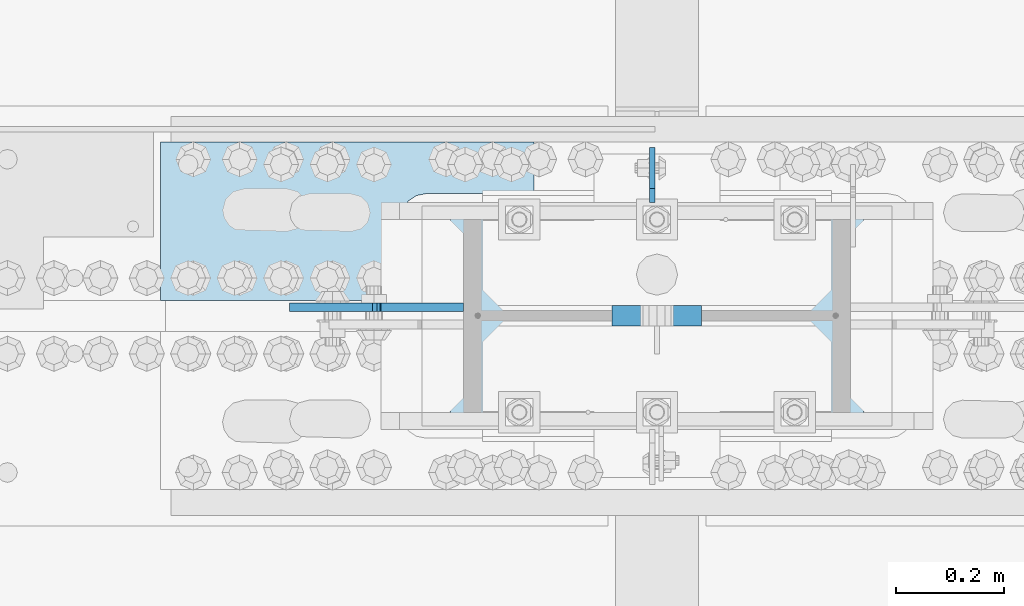
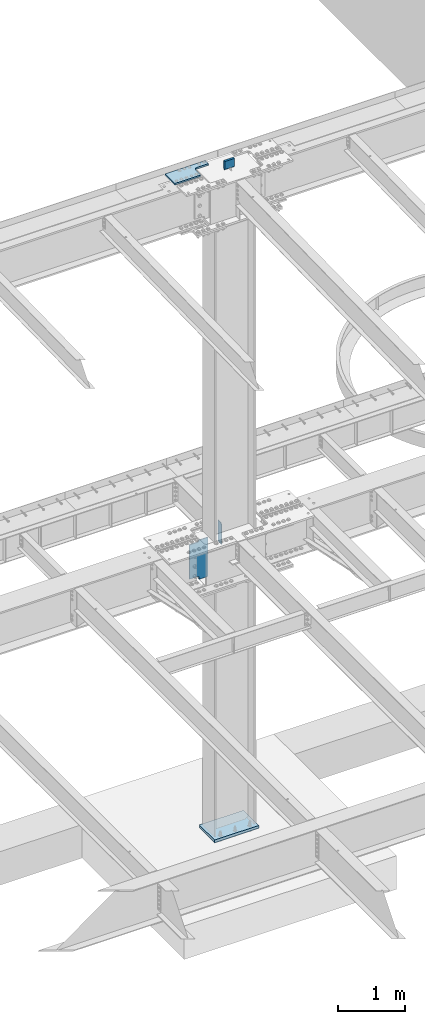
# One storey, part 1617 of 1763: 5 plates, 2 elements without a shape of their own.
"""IFC2X3 building model written with IfcOpenShell, lengths in millimetres."""

from ifc_helpers import new_model, si_unit, frame, origin_with_axes, place, context, subcontext, project, spatial, faceted_brep, material, type_object, element, aggregate, save


model = new_model("IFC2X3")

# Units and contexts
model_context = context("Model", 3, precision=1e-05, world=origin_with_axes())
body_context = subcontext(model_context, "Body", "Model", "MODEL_VIEW")
ifc_project = project(units=[si_unit("LENGTHUNIT", "METRE", prefix="MILLI"), si_unit("AREAUNIT", "SQUARE_METRE"), si_unit("VOLUMEUNIT", "CUBIC_METRE"), si_unit("MASSUNIT", "GRAM", prefix="KILO"), si_unit("TIMEUNIT", "SECOND"), si_unit("PLANEANGLEUNIT", "RADIAN"), si_unit("SOLIDANGLEUNIT", "STERADIAN"), si_unit("THERMODYNAMICTEMPERATUREUNIT", "DEGREE_CELSIUS"), si_unit("LUMINOUSINTENSITYUNIT", "LUMEN")], contexts=[model_context])

# Site, building, storey
site_placement = place(None, origin_with_axes())
site = spatial("IfcSite", under=ifc_project, at=site_placement, CompositionType="ELEMENT")
building_placement = place(site_placement, origin_with_axes())
building = spatial("IfcBuilding", under=site, at=building_placement, Name="Undefined", CompositionType="ELEMENT")
storey_placement = place(building_placement, origin_with_axes())
storey = spatial("IfcBuildingStorey", under=building, at=storey_placement, Name="Undefined", CompositionType="ELEMENT", Elevation=0.0)

# Assembly, plate
assembly_1_placement = place(storey_placement, origin_with_axes())
assembly_1 = element("IfcElementAssembly", 1, at=assembly_1_placement, inside=storey, Name="COLUMN", AssemblyPlace="NOTDEFINED", PredefinedType="RIGID_FRAME")
ifc_material_1 = material(Name="STEEL/A572-GR.50")
plate_type_1 = type_object("IfcPlateType", PredefinedType="NOTDEFINED")
plate_1_placement = place(assembly_1_placement, frame((-61603.1685236983, 52330.35, 5165.725), z_axis=(0.0, 1.0, 0.0), x_axis=(0.0, 0.0, -1.0)))
plate_1 = element("IfcPlate", 2, at=plate_1_placement, type_object=plate_type_1, material=ifc_material_1, Name="PLATE", context=body_context, shape_type="Brep", body=[
    faceted_brep([(25.3999996185303, -4.76250000000073, 0.0), (0.0, -4.76250000000073, 25.3999996185303), (0.0, 4.76250000000073, 25.3999996185303), (25.3999996185303, 4.76250000000073, 0.0), (1.45519152283669e-11, -4.76250000000448, 101.60001373291), (390.524993896484, -4.76249999999709, 101.599998474121), (390.524993896484, 4.76249999999709, 101.599998474121), (0.0, 4.76250000000243, 101.60001373291), (390.524993896484, -4.76249999999709, 0.0), (390.524993896484, 4.76249999999709, 0.0)], [[[0, 1, 2, 3]], [[4, 5, 6, 7]], [[5, 8, 9, 6]], [[9, 8, 0, 3]], [[7, 6, 9, 3, 2]], [[4, 7, 2, 1]], [[8, 5, 4, 1, 0]]]),
])

assembly_2_placement = place(storey_placement, origin_with_axes())
assembly_2 = element("IfcElementAssembly", 3, at=assembly_2_placement, inside=storey, Name="TOP PLATE", AssemblyPlace="NOTDEFINED", PredefinedType="RIGID_FRAME")
ifc_material_2 = material(Name="STEEL/A572-50")
plate_type_2 = type_object("IfcPlateType", PredefinedType="NOTDEFINED")
plate_2_placement = place(assembly_2_placement, frame((-62510.4247736984, 52149.3750002128, 11761.7874917654), z_axis=(0.0, 1.0, 0.0), x_axis=(1.0, 0.0, 0.0)))
plate_2 = element("IfcPlate", 4, at=plate_2_placement, type_object=plate_type_2, material=ifc_material_2, Name="TOP PLATE", context=body_context, shape_type="Brep", body=[
    faceted_brep([(0.0, -14.2875000000058, 0.0), (0.0, -14.2875000000004, 292.100006103516), (0.0, 14.2875000000004, 292.100006103516), (0.0, 14.2875000000058, 0.0), (688.974975585938, -14.2875000000004, 292.100006103516), (688.974975585938, 14.2875000000004, 292.100006103516), (688.974975585938, -14.2875000000004, 196.850006103516), (688.974975585938, 14.2875000000004, 196.850006103516), (488.950000762939, -14.2875000000004, 196.850006103516), (488.950000762939, 14.2875000000004, 196.850006103516), (471.939721902345, -14.2875000000004, 193.466451265565), (471.939721902345, 14.2875000000004, 193.466451265565), (457.519103799721, -14.2875000000004, 183.830902303795), (457.519103799721, 14.2875000000004, 183.830902303795), (447.88355483795, -14.2875000000004, 169.410284201171), (447.88355483795, 14.2875000000004, 169.410284201171), (444.5, -14.2875000000004, 152.400005340576), (444.5, 14.2875000000004, 152.400005340576), (444.5, -14.2875000000004, 0.0), (444.5, 14.2875000000004, 0.0)], [[[0, 1, 2, 3]], [[1, 4, 5, 2]], [[4, 6, 7, 5]], [[6, 8, 9, 7]], [[8, 10, 11, 9]], [[10, 12, 13, 11]], [[12, 14, 15, 13]], [[14, 16, 17, 15]], [[16, 18, 19, 17]], [[18, 0, 3, 19]], [[5, 7, 9, 11, 13, 15, 17, 19, 3, 2]], [[18, 16, 14, 12, 10, 8, 6, 4, 1, 0]]]),
])
aggregate(assembly_2, [plate_2])

# Plate
plate_type_3 = type_object("IfcPlateType", PredefinedType="NOTDEFINED")
plate_3_placement = place(assembly_1_placement, frame((-62272.2997736984, 52136.675, 4435.47562255859), z_axis=(1.0, 0.0, 0.0), x_axis=(0.0, 0.0, 1.0)))
plate_3 = element("IfcPlate", 5, at=plate_3_placement, type_object=plate_type_3, material=ifc_material_2, Name="SHEAR TAB", context=body_context, shape_type="Brep", body=[
    faceted_brep([(684.212475585938, -7.9375, 0.0), (684.212475585938, 7.9375, 0.0), (684.212475585938, 7.9375, 142.875009536743), (684.212475585938, -7.9375, 142.875009536743), (686.145935431114, 7.9375, 152.595168572821), (686.145935431114, -7.9375, 152.595168572821), (691.65196323207, 7.9375, 160.835521509129), (691.65196323207, -7.9375, 160.835521509129), (699.892316168377, 7.9375, 166.341549310091), (699.892316168377, -7.9375, 166.341549310091), (709.612475204468, 7.9375, 168.275009155273), (709.612475204468, -7.9375, 168.275009155273), (712.787475585938, -7.9375, 168.275009155273), (712.787475585938, 7.9375, 168.275009155273), (58.7375022888209, -7.9375, 142.875012588498), (58.7375022888209, 7.9375, 142.875012588498), (58.7375022888209, 7.9375, 0.0), (58.7375022888209, -7.9375, 0.0), (56.8040424436449, -7.9375, 152.595171624591), (56.8040424436449, 7.9375, 152.595171624591), (51.2980146426889, -7.9375, 160.835524560898), (51.2980146426889, 7.9375, 160.835524560898), (43.0576617063816, -7.9375, 166.341552361846), (43.0576617063816, 7.9375, 166.341552361846), (33.3375026702906, -7.9375, 168.275012207028), (33.3375026702906, 7.9375, 168.275012207028), (0.0, -7.9375, 168.275012207028), (0.0, 7.9375, 168.275012207028), (0.0, -7.9375, 320.674987792969), (0.0, 7.9375, 320.674987792969), (712.787475585938, -7.9375, 320.674987792969), (712.787475585938, 7.9375, 320.674987792969)], [[[0, 1, 2, 3]], [[3, 2, 4, 5]], [[5, 4, 6, 7]], [[7, 6, 8, 9]], [[9, 8, 10, 11]], [[12, 11, 10, 13]], [[14, 15, 16, 17]], [[18, 19, 15, 14]], [[20, 21, 19, 18]], [[22, 23, 21, 20]], [[24, 25, 23, 22]], [[26, 27, 25, 24]], [[28, 29, 27, 26]], [[28, 30, 31, 29]], [[31, 30, 12, 13]], [[8, 6, 4, 2, 1, 16, 15, 19, 21, 23, 25, 27, 29, 31, 13, 10]], [[17, 16, 1, 0]], [[30, 28, 26, 24, 22, 20, 18, 14, 17, 0, 3, 5, 7, 9, 11, 12]]]),
])

plate_type_4 = type_object("IfcPlateType", PredefinedType="NOTDEFINED")
plate_4_placement = place(assembly_1_placement, frame((-61511.8872721725, 52120.8, 11912.5999909009), z_axis=(0.0, 0.0, -1.0), x_axis=(-1.0, 0.0, 0.0)))
plate_4 = element("IfcPlate", 6, at=plate_4_placement, type_object=plate_type_4, material=ifc_material_2, Name="PLATE", context=body_context, shape_type="Brep", body=[
    faceted_brep([(0.0, 19.05, 146.049990844727), (-1.45519152283669e-11, 7.27595761418343e-12, 165.099990844727), (165.099990844727, 0.0, 165.099990844727), (165.099990844727, 19.05, 146.049990844727), (0.0, -19.05, 146.049990844727), (165.099990844727, -19.05, 146.049990844727), (0.0, 19.0500000000029, 0.0), (0.0, -19.0500000000029, 0.0), (165.10000190921, -19.0500000000029, 0.0), (165.10000190921, 19.0500000000029, 0.0)], [[[0, 1, 2, 3]], [[1, 4, 5, 2]], [[6, 7, 4, 1, 0]], [[5, 8, 9, 3, 2]], [[8, 7, 6, 9]], [[9, 6, 0, 3]], [[7, 8, 5, 4]]]),
])

ifc_material_3 = material(Name="STEEL/A36")
plate_type_5 = type_object("IfcPlateType", PredefinedType="NOTDEFINED")
plate_5_placement = place(assembly_1_placement, frame((-61975.4372736983, 51892.2, -241.299999999996), z_axis=(0.0, 1.0, 0.0), x_axis=(1.0, 0.0, 0.0)))
plate_5 = element("IfcPlate", 7, at=plate_5_placement, type_object=plate_type_5, material=ifc_material_3, Name="PLATE", context=body_context, shape_type="Brep", body=[
    faceted_brep([(0.0, -25.4000000000015, 0.0), (0.0, -25.4, 457.200012207031), (0.0, 25.4, 457.200012207031), (0.0, 25.4000000000015, 0.0), (762.0, -25.4, 457.200012207031), (762.0, 25.4, 457.200012207031), (762.0, -25.4, 0.0), (762.0, 25.4, 0.0)], [[[0, 1, 2, 3]], [[1, 4, 5, 2]], [[4, 6, 7, 5]], [[6, 0, 3, 7]], [[5, 7, 3, 2]], [[6, 4, 1, 0]]]),
])

aggregate(assembly_1, [plate_1, plate_3, plate_4, plate_5])

save(model, "model.ifc")
